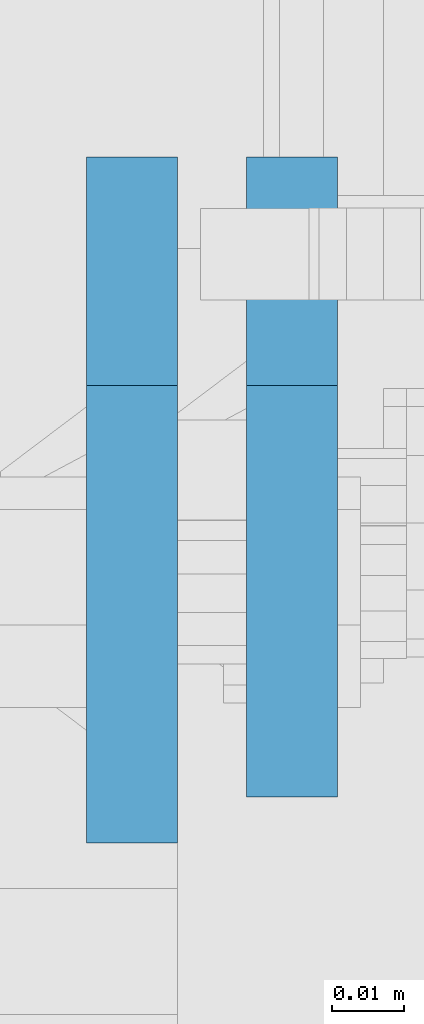
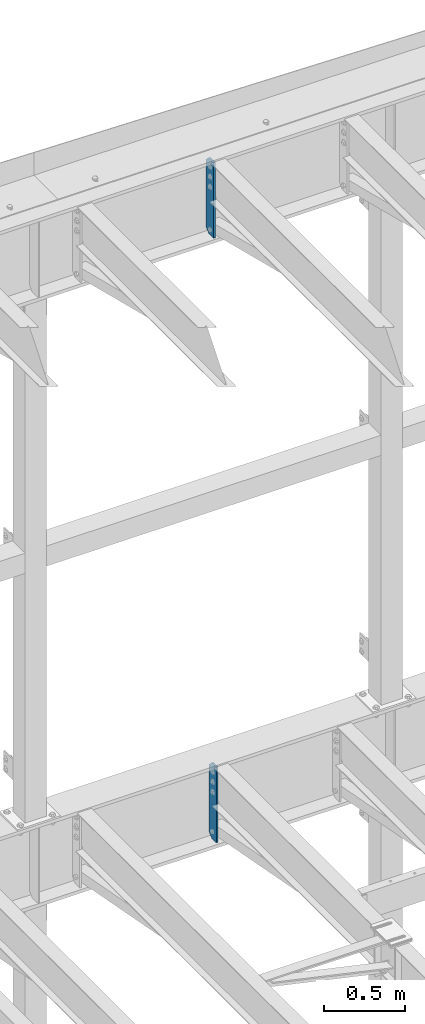
# One storey, part 1798 of 1876: 2 plates, 2 elements without a shape of their own.
"""IFC2X3 building model written with IfcOpenShell, lengths in millimetres."""

from ifc_helpers import new_model, si_unit, frame, origin_with_axes, place, context, subcontext, project, spatial, faceted_brep, material, type_object, element, aggregate, save


model = new_model("IFC2X3")

# Units and contexts
model_context = context("Model", 3, precision=1e-05, world=origin_with_axes())
body_context = subcontext(model_context, "Body", "Model", "MODEL_VIEW")
ifc_project = project(units=[si_unit("LENGTHUNIT", "METRE", prefix="MILLI"), si_unit("AREAUNIT", "SQUARE_METRE"), si_unit("VOLUMEUNIT", "CUBIC_METRE"), si_unit("MASSUNIT", "GRAM", prefix="KILO"), si_unit("TIMEUNIT", "SECOND"), si_unit("PLANEANGLEUNIT", "RADIAN"), si_unit("SOLIDANGLEUNIT", "STERADIAN"), si_unit("THERMODYNAMICTEMPERATUREUNIT", "DEGREE_CELSIUS"), si_unit("LUMINOUSINTENSITYUNIT", "LUMEN")], contexts=[model_context])

# Site, building, storey
site_placement = place(None, origin_with_axes())
site = spatial("IfcSite", under=ifc_project, at=site_placement, CompositionType="ELEMENT")
building_placement = place(site_placement, origin_with_axes())
building = spatial("IfcBuilding", under=site, at=building_placement, Name="Undefined", CompositionType="ELEMENT")
storey_placement = place(building_placement, origin_with_axes())
storey = spatial("IfcBuildingStorey", under=building, at=storey_placement, Name="Undefined", CompositionType="ELEMENT", Elevation=0.0)

# Assembly, plate
assembly_1_placement = place(storey_placement, origin_with_axes())
assembly_1 = element("IfcElementAssembly", 1, at=assembly_1_placement, inside=storey, Name="BEAM", AssemblyPlace="NOTDEFINED", PredefinedType="RIGID_FRAME")
ifc_material = material(Name="STEEL/A36")
plate_type_1 = type_object("IfcPlateType", PredefinedType="NOTDEFINED")
plate_1_placement = place(assembly_1_placement, frame((3822.69999990463, 13708.85625, 17386.3), z_axis=(0.0, 0.0, 1.0), x_axis=(0.0, -1.0, 0.0)))
plate_1 = element("IfcPlate", 2, at=plate_1_placement, type_object=plate_type_1, material=ifc_material, Name="PLATE", context=body_context, shape_type="Brep", body=[
    faceted_brep([(0.0, -6.34999999999991, 31.75), (0.0, -6.34999999999991, 539.75), (0.0, 6.34999999999991, 539.75), (0.0, 6.34999999999991, 31.75), (31.75, -6.34999999999991, 571.5), (31.75, 6.34999999999991, 571.5), (88.9000015258789, -6.34999999999991, 571.5), (88.9000015258789, 6.34999999999991, 571.5), (88.9000015258789, -6.34999999999991, 0.0), (88.9000015258789, 6.34999999999991, 0.0), (31.75, -6.34999999999991, 0.0), (31.75, 6.34999999999991, 0.0)], [[[0, 1, 2, 3]], [[1, 4, 5, 2]], [[4, 6, 7, 5]], [[6, 8, 9, 7]], [[8, 10, 11, 9]], [[10, 0, 3, 11]], [[5, 7, 9, 11, 3, 2]], [[10, 8, 6, 4, 1, 0]]]),
])
aggregate(assembly_1, [plate_1])

assembly_2_placement = place(storey_placement, origin_with_axes())
assembly_2 = element("IfcElementAssembly", 3, at=assembly_2_placement, inside=storey, Name="BEAM", AssemblyPlace="NOTDEFINED", PredefinedType="RIGID_FRAME")
plate_type_2 = type_object("IfcPlateType", PredefinedType="NOTDEFINED")
plate_2_placement = place(assembly_2_placement, frame((3800.47499990463, 13708.85625, 21959.8875), z_axis=(0.0, 0.0, 1.0), x_axis=(0.0, -1.0, 0.0)))
plate_2 = element("IfcPlate", 4, at=plate_2_placement, type_object=plate_type_2, material=ifc_material, Name="PLATE", context=body_context, shape_type="Brep", body=[
    faceted_brep([(0.0, -6.34999999999991, 31.75), (0.0, -6.35000000000036, 538.162475585938), (0.0, 6.35000000000036, 538.162475585938), (0.0, 6.34999999999991, 31.75), (31.75, -6.35000000000036, 569.912475585938), (31.75, 6.35000000000036, 569.912475585938), (95.25, -6.35000000000036, 569.912475585938), (95.25, 6.35000000000036, 569.912475585938), (95.25, -6.35000000000036, 0.0), (95.25, 6.35000000000036, 0.0), (31.75, -6.34999999999991, 0.0), (31.75, 6.34999999999991, 0.0)], [[[0, 1, 2, 3]], [[1, 4, 5, 2]], [[4, 6, 7, 5]], [[6, 8, 9, 7]], [[8, 10, 11, 9]], [[10, 0, 3, 11]], [[5, 7, 9, 11, 3, 2]], [[10, 8, 6, 4, 1, 0]]]),
])
aggregate(assembly_2, [plate_2])

save(model, "model.ifc")
